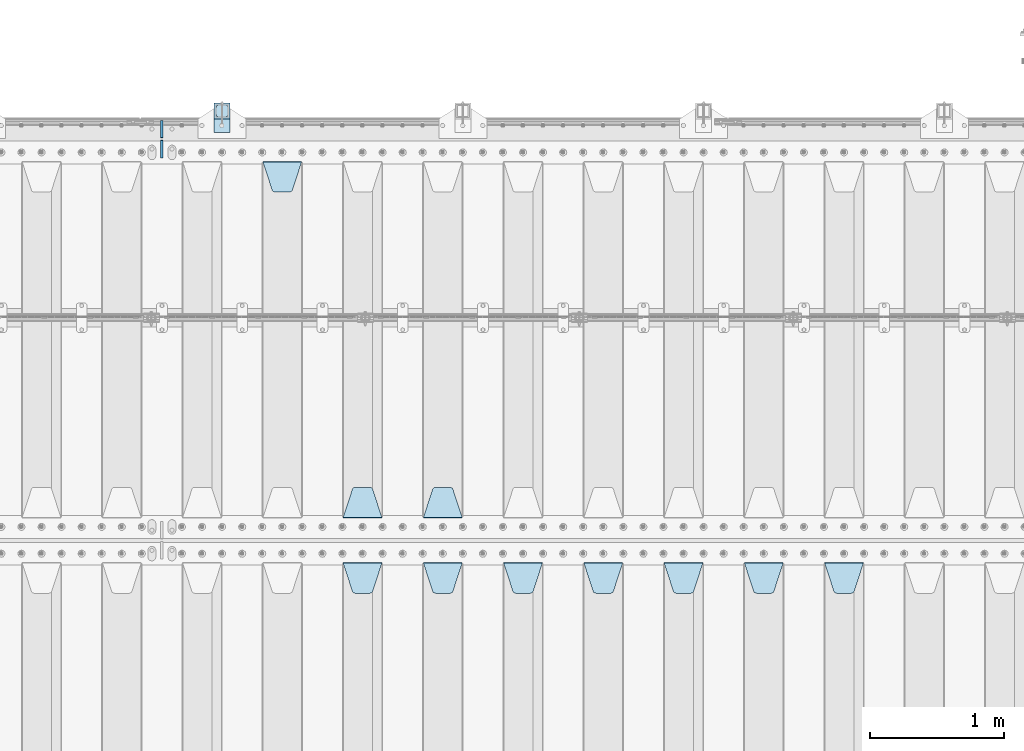
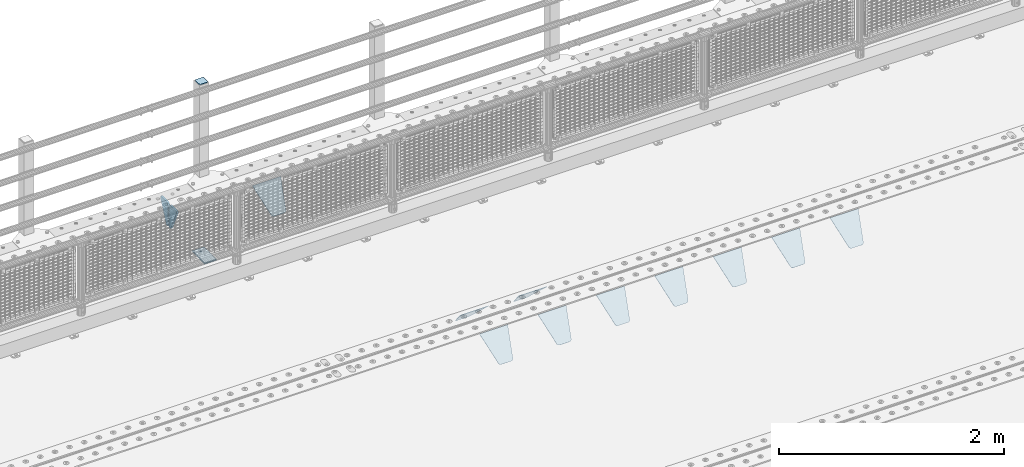
# One storey, part 224 of 257: 15 plates.
"""IFC2X3 building model written with IfcOpenShell, lengths in millimetres."""

from ifc_helpers import new_model, si_unit, frame, origin_with_axes, place, context, subcontext, project, spatial, faceted_brep, material, type_object, element, save


model = new_model("IFC2X3")

# Units and contexts
model_context = context("Model", 3, precision=1e-05, world=origin_with_axes())
body_context = subcontext(model_context, "Body", "Model", "MODEL_VIEW")
ifc_project = project(units=[si_unit("LENGTHUNIT", "METRE", prefix="MILLI"), si_unit("AREAUNIT", "SQUARE_METRE"), si_unit("VOLUMEUNIT", "CUBIC_METRE"), si_unit("MASSUNIT", "GRAM", prefix="KILO"), si_unit("TIMEUNIT", "SECOND"), si_unit("PLANEANGLEUNIT", "RADIAN"), si_unit("SOLIDANGLEUNIT", "STERADIAN"), si_unit("THERMODYNAMICTEMPERATUREUNIT", "DEGREE_CELSIUS"), si_unit("LUMINOUSINTENSITYUNIT", "LUMEN")], contexts=[model_context])

# Site, building, storey
site_placement = place(None, origin_with_axes())
site = spatial("IfcSite", under=ifc_project, at=site_placement, CompositionType="ELEMENT")
building_placement = place(site_placement, origin_with_axes())
building = spatial("IfcBuilding", under=site, at=building_placement, Name="Standard", CompositionType="ELEMENT")
storey_placement = place(building_placement, origin_with_axes())
storey = spatial("IfcBuildingStorey", under=building, at=storey_placement, Name="Undefined", CompositionType="ELEMENT", Elevation=0.0)

# Plates
ifc_material_1 = material(Name="STEEL/S355N")
plate_type_1 = type_object("IfcPlateType", PredefinedType="NOTDEFINED")
plate_1_placement = place(storey_placement, frame((52905.0, 8831.76776695594, -1.767766952965), z_axis=(0.0, -0.707106781186548, -0.707106781186547), x_axis=(1.0, 0.0, 0.0)))
element("IfcPlate", 1, at=plate_1_placement, inside=storey, type_object=plate_type_1, material=ifc_material_1, context=body_context, shape_type="Brep", body=[
    faceted_brep([(0.0, -2.5, 0.0), (69.345504679477, -2.50000000000091, 300.17173142483), (69.345504679477, 2.5, 300.171731424831), (0.0, 2.5, 0.0), (70.927406119954, -2.50000000000091, 304.8974424154), (70.927406119954, 2.5, 304.8974424154), (73.3818627772271, -2.50000000000091, 309.234538108527), (73.3818627772271, 2.49999999999909, 309.234538108527), (76.6187032999587, -2.5, 313.023683126103), (76.6187032999587, 2.5, 313.023683126103), (80.5190132705029, -2.5, 316.125672595372), (80.5190132705029, 2.5, 316.125672595371), (84.9395038596849, -2.5, 318.426546230476), (84.9395038596849, 2.5, 318.426546230477), (89.7177759439219, -2.5, 319.841774983275), (89.7177759439219, 2.5, 319.841774983275), (94.6782862926484, -2.5, 320.319366455079), (94.6782862926484, 2.5, 320.319366455079), (195.321713707352, -2.5, 320.319366455079), (195.321713707352, 2.5, 320.319366455079), (200.282224056078, -2.5, 319.841774983275), (200.282224056078, 2.49999999999909, 319.841774983275), (205.060496140315, -2.5, 318.426546230476), (205.060496140315, 2.49999999999909, 318.426546230475), (209.480986729497, -2.5, 316.125672595371), (209.480986729497, 2.5, 316.125672595371), (213.381296700041, -2.50000000000091, 313.023683126102), (213.381296700041, 2.5, 313.023683126103), (216.618137222766, -2.50000000000091, 309.234538108527), (216.618137222766, 2.5, 309.234538108527), (219.072593880039, -2.5, 304.897442415399), (219.072593880039, 2.5, 304.897442415399), (220.654495320523, -2.50000000000091, 300.17173142483), (220.654495320523, 2.5, 300.171731424831), (290.0, -2.50000000000091, 0.0), (290.0, 2.5, 9.09494701772928e-13)], [[[0, 1, 2, 3]], [[1, 4, 5, 2]], [[4, 6, 7, 5]], [[6, 8, 9, 7]], [[8, 10, 11, 9]], [[10, 12, 13, 11]], [[12, 14, 15, 13]], [[14, 16, 17, 15]], [[16, 18, 19, 17]], [[18, 20, 21, 19]], [[20, 22, 23, 21]], [[22, 24, 25, 23]], [[24, 26, 27, 25]], [[26, 28, 29, 27]], [[28, 30, 31, 29]], [[30, 32, 33, 31]], [[32, 34, 35, 33]], [[34, 0, 3, 35]], [[5, 7, 9, 11, 13, 15, 17, 19, 21, 23, 25, 27, 29, 31, 33, 35, 3, 2]], [[34, 32, 30, 28, 26, 24, 22, 20, 18, 16, 14, 12, 10, 8, 6, 4, 1, 0]]]),
])
plate_2_placement = place(storey_placement, frame((52305.0, 8831.76776695594, -1.767766952965), z_axis=(0.0, -0.707106781186548, -0.707106781186547), x_axis=(1.0, 0.0, 0.0)))
element("IfcPlate", 2, at=plate_2_placement, inside=storey, type_object=plate_type_1, material=ifc_material_1, context=body_context, shape_type="Brep", body=[
    faceted_brep([(0.0, -2.5, 0.0), (69.345504679477, -2.50000000000091, 300.17173142483), (69.345504679477, 2.5, 300.171731424831), (0.0, 2.5, 0.0), (70.927406119954, -2.50000000000091, 304.8974424154), (70.927406119954, 2.5, 304.8974424154), (73.3818627772271, -2.50000000000091, 309.234538108527), (73.3818627772271, 2.49999999999909, 309.234538108527), (76.6187032999587, -2.5, 313.023683126103), (76.6187032999587, 2.5, 313.023683126103), (80.5190132705029, -2.5, 316.125672595372), (80.5190132705029, 2.5, 316.125672595371), (84.9395038596849, -2.5, 318.426546230476), (84.9395038596849, 2.5, 318.426546230477), (89.7177759439219, -2.5, 319.841774983275), (89.7177759439219, 2.5, 319.841774983275), (94.6782862926484, -2.5, 320.319366455079), (94.6782862926484, 2.5, 320.319366455079), (195.321713707352, -2.5, 320.319366455079), (195.321713707352, 2.5, 320.319366455079), (200.282224056078, -2.5, 319.841774983275), (200.282224056078, 2.49999999999909, 319.841774983275), (205.060496140315, -2.5, 318.426546230476), (205.060496140315, 2.49999999999909, 318.426546230475), (209.480986729497, -2.5, 316.125672595371), (209.480986729497, 2.5, 316.125672595371), (213.381296700041, -2.50000000000091, 313.023683126102), (213.381296700041, 2.5, 313.023683126103), (216.618137222766, -2.50000000000091, 309.234538108527), (216.618137222766, 2.5, 309.234538108527), (219.072593880039, -2.5, 304.897442415399), (219.072593880039, 2.5, 304.897442415399), (220.654495320523, -2.50000000000091, 300.17173142483), (220.654495320523, 2.5, 300.171731424831), (290.0, -2.50000000000091, 0.0), (290.0, 2.5, 9.09494701772928e-13)], [[[0, 1, 2, 3]], [[1, 4, 5, 2]], [[4, 6, 7, 5]], [[6, 8, 9, 7]], [[8, 10, 11, 9]], [[10, 12, 13, 11]], [[12, 14, 15, 13]], [[14, 16, 17, 15]], [[16, 18, 19, 17]], [[18, 20, 21, 19]], [[20, 22, 23, 21]], [[22, 24, 25, 23]], [[24, 26, 27, 25]], [[26, 28, 29, 27]], [[28, 30, 31, 29]], [[30, 32, 33, 31]], [[32, 34, 35, 33]], [[34, 0, 3, 35]], [[5, 7, 9, 11, 13, 15, 17, 19, 21, 23, 25, 27, 29, 31, 33, 35, 3, 2]], [[34, 32, 30, 28, 26, 24, 22, 20, 18, 16, 14, 12, 10, 8, 6, 4, 1, 0]]]),
])
plate_3_placement = place(storey_placement, frame((51705.0, 8831.76776695594, -1.767766952965), z_axis=(0.0, -0.707106781186548, -0.707106781186547), x_axis=(1.0, 0.0, 0.0)))
element("IfcPlate", 3, at=plate_3_placement, inside=storey, type_object=plate_type_1, material=ifc_material_1, context=body_context, shape_type="Brep", body=[
    faceted_brep([(0.0, -2.5, 0.0), (69.345504679477, -2.50000000000091, 300.17173142483), (69.345504679477, 2.5, 300.171731424831), (0.0, 2.5, 0.0), (70.927406119954, -2.50000000000091, 304.8974424154), (70.927406119954, 2.5, 304.8974424154), (73.3818627772271, -2.50000000000091, 309.234538108527), (73.3818627772271, 2.49999999999909, 309.234538108527), (76.6187032999587, -2.5, 313.023683126103), (76.6187032999587, 2.5, 313.023683126103), (80.5190132705029, -2.5, 316.125672595372), (80.5190132705029, 2.5, 316.125672595371), (84.9395038596849, -2.5, 318.426546230476), (84.9395038596849, 2.5, 318.426546230477), (89.7177759439219, -2.5, 319.841774983275), (89.7177759439219, 2.5, 319.841774983275), (94.6782862926484, -2.5, 320.319366455079), (94.6782862926484, 2.5, 320.319366455079), (195.321713707352, -2.5, 320.319366455079), (195.321713707352, 2.5, 320.319366455079), (200.282224056078, -2.5, 319.841774983275), (200.282224056078, 2.49999999999909, 319.841774983275), (205.060496140315, -2.5, 318.426546230476), (205.060496140315, 2.49999999999909, 318.426546230475), (209.480986729497, -2.5, 316.125672595371), (209.480986729497, 2.5, 316.125672595371), (213.381296700041, -2.50000000000091, 313.023683126102), (213.381296700041, 2.5, 313.023683126103), (216.618137222766, -2.50000000000091, 309.234538108527), (216.618137222766, 2.5, 309.234538108527), (219.072593880039, -2.5, 304.897442415399), (219.072593880039, 2.5, 304.897442415399), (220.654495320523, -2.50000000000091, 300.17173142483), (220.654495320523, 2.5, 300.171731424831), (290.0, -2.50000000000091, 0.0), (290.0, 2.5, 9.09494701772928e-13)], [[[0, 1, 2, 3]], [[1, 4, 5, 2]], [[4, 6, 7, 5]], [[6, 8, 9, 7]], [[8, 10, 11, 9]], [[10, 12, 13, 11]], [[12, 14, 15, 13]], [[14, 16, 17, 15]], [[16, 18, 19, 17]], [[18, 20, 21, 19]], [[20, 22, 23, 21]], [[22, 24, 25, 23]], [[24, 26, 27, 25]], [[26, 28, 29, 27]], [[28, 30, 31, 29]], [[30, 32, 33, 31]], [[32, 34, 35, 33]], [[34, 0, 3, 35]], [[5, 7, 9, 11, 13, 15, 17, 19, 21, 23, 25, 27, 29, 31, 33, 35, 3, 2]], [[34, 32, 30, 28, 26, 24, 22, 20, 18, 16, 14, 12, 10, 8, 6, 4, 1, 0]]]),
])
plate_4_placement = place(storey_placement, frame((51105.0, 8831.76776695594, -1.767766952965), z_axis=(0.0, -0.707106781186548, -0.707106781186547), x_axis=(1.0, 0.0, 0.0)))
element("IfcPlate", 4, at=plate_4_placement, inside=storey, type_object=plate_type_1, material=ifc_material_1, context=body_context, shape_type="Brep", body=[
    faceted_brep([(0.0, -2.5, 0.0), (69.345504679477, -2.50000000000091, 300.17173142483), (69.345504679477, 2.5, 300.171731424831), (0.0, 2.5, 0.0), (70.927406119954, -2.50000000000091, 304.8974424154), (70.927406119954, 2.5, 304.8974424154), (73.3818627772271, -2.50000000000091, 309.234538108527), (73.3818627772271, 2.49999999999909, 309.234538108527), (76.6187032999587, -2.5, 313.023683126103), (76.6187032999587, 2.5, 313.023683126103), (80.5190132705029, -2.5, 316.125672595372), (80.5190132705029, 2.5, 316.125672595371), (84.9395038596849, -2.5, 318.426546230476), (84.9395038596849, 2.5, 318.426546230477), (89.7177759439219, -2.5, 319.841774983275), (89.7177759439219, 2.5, 319.841774983275), (94.6782862926484, -2.5, 320.319366455079), (94.6782862926484, 2.5, 320.319366455079), (195.321713707352, -2.5, 320.319366455079), (195.321713707352, 2.5, 320.319366455079), (200.282224056078, -2.5, 319.841774983275), (200.282224056078, 2.49999999999909, 319.841774983275), (205.060496140315, -2.5, 318.426546230476), (205.060496140315, 2.49999999999909, 318.426546230475), (209.480986729497, -2.5, 316.125672595371), (209.480986729497, 2.5, 316.125672595371), (213.381296700041, -2.50000000000091, 313.023683126102), (213.381296700041, 2.5, 313.023683126103), (216.618137222766, -2.50000000000091, 309.234538108527), (216.618137222766, 2.5, 309.234538108527), (219.072593880039, -2.5, 304.897442415399), (219.072593880039, 2.5, 304.897442415399), (220.654495320523, -2.50000000000091, 300.17173142483), (220.654495320523, 2.5, 300.171731424831), (290.0, -2.50000000000091, 0.0), (290.0, 2.5, 9.09494701772928e-13)], [[[0, 1, 2, 3]], [[1, 4, 5, 2]], [[4, 6, 7, 5]], [[6, 8, 9, 7]], [[8, 10, 11, 9]], [[10, 12, 13, 11]], [[12, 14, 15, 13]], [[14, 16, 17, 15]], [[16, 18, 19, 17]], [[18, 20, 21, 19]], [[20, 22, 23, 21]], [[22, 24, 25, 23]], [[24, 26, 27, 25]], [[26, 28, 29, 27]], [[28, 30, 31, 29]], [[30, 32, 33, 31]], [[32, 34, 35, 33]], [[34, 0, 3, 35]], [[5, 7, 9, 11, 13, 15, 17, 19, 21, 23, 25, 27, 29, 31, 33, 35, 3, 2]], [[34, 32, 30, 28, 26, 24, 22, 20, 18, 16, 14, 12, 10, 8, 6, 4, 1, 0]]]),
])
plate_5_placement = place(storey_placement, frame((50505.0, 8831.76776695594, -1.767766952965), z_axis=(0.0, -0.707106781186548, -0.707106781186547), x_axis=(1.0, 0.0, 0.0)))
element("IfcPlate", 5, at=plate_5_placement, inside=storey, type_object=plate_type_1, material=ifc_material_1, context=body_context, shape_type="Brep", body=[
    faceted_brep([(0.0, -2.5, 0.0), (69.345504679477, -2.50000000000091, 300.17173142483), (69.345504679477, 2.5, 300.171731424831), (0.0, 2.5, 0.0), (70.927406119954, -2.50000000000091, 304.8974424154), (70.927406119954, 2.5, 304.8974424154), (73.3818627772271, -2.50000000000091, 309.234538108527), (73.3818627772271, 2.49999999999909, 309.234538108527), (76.6187032999587, -2.5, 313.023683126103), (76.6187032999587, 2.5, 313.023683126103), (80.5190132705029, -2.5, 316.125672595372), (80.5190132705029, 2.5, 316.125672595371), (84.9395038596849, -2.5, 318.426546230476), (84.9395038596849, 2.5, 318.426546230477), (89.7177759439219, -2.5, 319.841774983275), (89.7177759439219, 2.5, 319.841774983275), (94.6782862926484, -2.5, 320.319366455079), (94.6782862926484, 2.5, 320.319366455079), (195.321713707352, -2.5, 320.319366455079), (195.321713707352, 2.5, 320.319366455079), (200.282224056078, -2.5, 319.841774983275), (200.282224056078, 2.49999999999909, 319.841774983275), (205.060496140315, -2.5, 318.426546230476), (205.060496140315, 2.49999999999909, 318.426546230475), (209.480986729497, -2.5, 316.125672595371), (209.480986729497, 2.5, 316.125672595371), (213.381296700041, -2.50000000000091, 313.023683126102), (213.381296700041, 2.5, 313.023683126103), (216.618137222766, -2.50000000000091, 309.234538108527), (216.618137222766, 2.5, 309.234538108527), (219.072593880039, -2.5, 304.897442415399), (219.072593880039, 2.5, 304.897442415399), (220.654495320523, -2.50000000000091, 300.17173142483), (220.654495320523, 2.5, 300.171731424831), (290.0, -2.50000000000091, 0.0), (290.0, 2.5, 9.09494701772928e-13)], [[[0, 1, 2, 3]], [[1, 4, 5, 2]], [[4, 6, 7, 5]], [[6, 8, 9, 7]], [[8, 10, 11, 9]], [[10, 12, 13, 11]], [[12, 14, 15, 13]], [[14, 16, 17, 15]], [[16, 18, 19, 17]], [[18, 20, 21, 19]], [[20, 22, 23, 21]], [[22, 24, 25, 23]], [[24, 26, 27, 25]], [[26, 28, 29, 27]], [[28, 30, 31, 29]], [[30, 32, 33, 31]], [[32, 34, 35, 33]], [[34, 0, 3, 35]], [[5, 7, 9, 11, 13, 15, 17, 19, 21, 23, 25, 27, 29, 31, 33, 35, 3, 2]], [[34, 32, 30, 28, 26, 24, 22, 20, 18, 16, 14, 12, 10, 8, 6, 4, 1, 0]]]),
])
plate_6_placement = place(storey_placement, frame((49905.0, 8831.76776695594, -1.767766952965), z_axis=(0.0, -0.707106781186548, -0.707106781186547), x_axis=(1.0, 0.0, 0.0)))
element("IfcPlate", 6, at=plate_6_placement, inside=storey, type_object=plate_type_1, material=ifc_material_1, context=body_context, shape_type="Brep", body=[
    faceted_brep([(0.0, -2.5, 0.0), (69.345504679477, -2.50000000000091, 300.17173142483), (69.345504679477, 2.5, 300.171731424831), (0.0, 2.5, 0.0), (70.927406119954, -2.50000000000091, 304.8974424154), (70.927406119954, 2.5, 304.8974424154), (73.3818627772271, -2.50000000000091, 309.234538108527), (73.3818627772271, 2.49999999999909, 309.234538108527), (76.6187032999587, -2.5, 313.023683126103), (76.6187032999587, 2.5, 313.023683126103), (80.5190132705029, -2.5, 316.125672595372), (80.5190132705029, 2.5, 316.125672595371), (84.9395038596849, -2.5, 318.426546230476), (84.9395038596849, 2.5, 318.426546230477), (89.7177759439219, -2.5, 319.841774983275), (89.7177759439219, 2.5, 319.841774983275), (94.6782862926484, -2.5, 320.319366455079), (94.6782862926484, 2.5, 320.319366455079), (195.321713707352, -2.5, 320.319366455079), (195.321713707352, 2.5, 320.319366455079), (200.282224056078, -2.5, 319.841774983275), (200.282224056078, 2.49999999999909, 319.841774983275), (205.060496140315, -2.5, 318.426546230476), (205.060496140315, 2.49999999999909, 318.426546230475), (209.480986729497, -2.5, 316.125672595371), (209.480986729497, 2.5, 316.125672595371), (213.381296700041, -2.50000000000091, 313.023683126102), (213.381296700041, 2.5, 313.023683126103), (216.618137222766, -2.50000000000091, 309.234538108527), (216.618137222766, 2.5, 309.234538108527), (219.072593880039, -2.5, 304.897442415399), (219.072593880039, 2.5, 304.897442415399), (220.654495320523, -2.50000000000091, 300.17173142483), (220.654495320523, 2.5, 300.171731424831), (290.0, -2.50000000000091, 0.0), (290.0, 2.5, 9.09494701772928e-13)], [[[0, 1, 2, 3]], [[1, 4, 5, 2]], [[4, 6, 7, 5]], [[6, 8, 9, 7]], [[8, 10, 11, 9]], [[10, 12, 13, 11]], [[12, 14, 15, 13]], [[14, 16, 17, 15]], [[16, 18, 19, 17]], [[18, 20, 21, 19]], [[20, 22, 23, 21]], [[22, 24, 25, 23]], [[24, 26, 27, 25]], [[26, 28, 29, 27]], [[28, 30, 31, 29]], [[30, 32, 33, 31]], [[32, 34, 35, 33]], [[34, 0, 3, 35]], [[5, 7, 9, 11, 13, 15, 17, 19, 21, 23, 25, 27, 29, 31, 33, 35, 3, 2]], [[34, 32, 30, 28, 26, 24, 22, 20, 18, 16, 14, 12, 10, 8, 6, 4, 1, 0]]]),
])
plate_7_placement = place(storey_placement, frame((49305.0, 8831.76776695594, -1.767766952965), z_axis=(0.0, -0.707106781186548, -0.707106781186547), x_axis=(1.0, 0.0, 0.0)))
element("IfcPlate", 7, at=plate_7_placement, inside=storey, type_object=plate_type_1, material=ifc_material_1, context=body_context, shape_type="Brep", body=[
    faceted_brep([(0.0, -2.5, 0.0), (69.345504679477, -2.50000000000091, 300.17173142483), (69.345504679477, 2.5, 300.171731424831), (0.0, 2.5, 0.0), (70.927406119954, -2.50000000000091, 304.8974424154), (70.927406119954, 2.5, 304.8974424154), (73.3818627772271, -2.50000000000091, 309.234538108527), (73.3818627772271, 2.49999999999909, 309.234538108527), (76.6187032999587, -2.5, 313.023683126103), (76.6187032999587, 2.5, 313.023683126103), (80.5190132705029, -2.5, 316.125672595372), (80.5190132705029, 2.5, 316.125672595371), (84.9395038596849, -2.5, 318.426546230476), (84.9395038596849, 2.5, 318.426546230477), (89.7177759439219, -2.5, 319.841774983275), (89.7177759439219, 2.5, 319.841774983275), (94.6782862926484, -2.5, 320.319366455079), (94.6782862926484, 2.5, 320.319366455079), (195.321713707352, -2.5, 320.319366455079), (195.321713707352, 2.5, 320.319366455079), (200.282224056078, -2.5, 319.841774983275), (200.282224056078, 2.49999999999909, 319.841774983275), (205.060496140315, -2.5, 318.426546230476), (205.060496140315, 2.49999999999909, 318.426546230475), (209.480986729497, -2.5, 316.125672595371), (209.480986729497, 2.5, 316.125672595371), (213.381296700041, -2.50000000000091, 313.023683126102), (213.381296700041, 2.5, 313.023683126103), (216.618137222766, -2.50000000000091, 309.234538108527), (216.618137222766, 2.5, 309.234538108527), (219.072593880039, -2.5, 304.897442415399), (219.072593880039, 2.5, 304.897442415399), (220.654495320523, -2.50000000000091, 300.17173142483), (220.654495320523, 2.5, 300.171731424831), (290.0, -2.50000000000091, 0.0), (290.0, 2.5, 9.09494701772928e-13)], [[[0, 1, 2, 3]], [[1, 4, 5, 2]], [[4, 6, 7, 5]], [[6, 8, 9, 7]], [[8, 10, 11, 9]], [[10, 12, 13, 11]], [[12, 14, 15, 13]], [[14, 16, 17, 15]], [[16, 18, 19, 17]], [[18, 20, 21, 19]], [[20, 22, 23, 21]], [[22, 24, 25, 23]], [[24, 26, 27, 25]], [[26, 28, 29, 27]], [[28, 30, 31, 29]], [[30, 32, 33, 31]], [[32, 34, 35, 33]], [[34, 0, 3, 35]], [[5, 7, 9, 11, 13, 15, 17, 19, 21, 23, 25, 27, 29, 31, 33, 35, 3, 2]], [[34, 32, 30, 28, 26, 24, 22, 20, 18, 16, 14, 12, 10, 8, 6, 4, 1, 0]]]),
])
plate_8_placement = place(storey_placement, frame((50195.0, 9168.23223304703, -1.76776695296758), z_axis=(0.0, 0.707106781186547, -0.707106781186548), x_axis=(-1.0, 0.0, 0.0)))
element("IfcPlate", 8, at=plate_8_placement, inside=storey, type_object=plate_type_1, material=ifc_material_1, context=body_context, shape_type="Brep", body=[
    faceted_brep([(0.0, -2.5, 0.0), (69.345504679477, -2.50000000000091, 300.17173142483), (69.345504679477, 2.5, 300.171731424831), (0.0, 2.5, 0.0), (70.927406119954, -2.50000000000091, 304.8974424154), (70.927406119954, 2.5, 304.8974424154), (73.3818627772271, -2.50000000000091, 309.234538108527), (73.3818627772271, 2.49999999999909, 309.234538108527), (76.6187032999587, -2.5, 313.023683126103), (76.6187032999587, 2.5, 313.023683126103), (80.5190132705029, -2.5, 316.125672595372), (80.5190132705029, 2.5, 316.125672595371), (84.9395038596849, -2.5, 318.426546230476), (84.9395038596849, 2.5, 318.426546230477), (89.7177759439219, -2.5, 319.841774983275), (89.7177759439219, 2.5, 319.841774983275), (94.6782862926484, -2.5, 320.319366455079), (94.6782862926484, 2.5, 320.319366455079), (195.321713707352, -2.5, 320.319366455079), (195.321713707352, 2.5, 320.319366455079), (200.282224056078, -2.5, 319.841774983275), (200.282224056078, 2.49999999999909, 319.841774983275), (205.060496140315, -2.5, 318.426546230476), (205.060496140315, 2.49999999999909, 318.426546230475), (209.480986729497, -2.5, 316.125672595371), (209.480986729497, 2.5, 316.125672595371), (213.381296700041, -2.50000000000091, 313.023683126102), (213.381296700041, 2.5, 313.023683126103), (216.618137222766, -2.50000000000091, 309.234538108527), (216.618137222766, 2.5, 309.234538108527), (219.072593880039, -2.5, 304.897442415399), (219.072593880039, 2.5, 304.897442415399), (220.654495320523, -2.50000000000091, 300.17173142483), (220.654495320523, 2.5, 300.171731424831), (290.0, -2.50000000000091, 0.0), (290.0, 2.5, 9.09494701772928e-13)], [[[0, 1, 2, 3]], [[1, 4, 5, 2]], [[4, 6, 7, 5]], [[6, 8, 9, 7]], [[8, 10, 11, 9]], [[10, 12, 13, 11]], [[12, 14, 15, 13]], [[14, 16, 17, 15]], [[16, 18, 19, 17]], [[18, 20, 21, 19]], [[20, 22, 23, 21]], [[22, 24, 25, 23]], [[24, 26, 27, 25]], [[26, 28, 29, 27]], [[28, 30, 31, 29]], [[30, 32, 33, 31]], [[32, 34, 35, 33]], [[34, 0, 3, 35]], [[5, 7, 9, 11, 13, 15, 17, 19, 21, 23, 25, 27, 29, 31, 33, 35, 3, 2]], [[34, 32, 30, 28, 26, 24, 22, 20, 18, 16, 14, 12, 10, 8, 6, 4, 1, 0]]]),
])
plate_9_placement = place(storey_placement, frame((49595.0, 9168.23223304703, -1.76776695296758), z_axis=(0.0, 0.707106781186547, -0.707106781186548), x_axis=(-1.0, 0.0, 0.0)))
element("IfcPlate", 9, at=plate_9_placement, inside=storey, type_object=plate_type_1, material=ifc_material_1, context=body_context, shape_type="Brep", body=[
    faceted_brep([(0.0, -2.5, 0.0), (69.345504679477, -2.50000000000091, 300.17173142483), (69.345504679477, 2.5, 300.171731424831), (0.0, 2.5, 0.0), (70.927406119954, -2.50000000000091, 304.8974424154), (70.927406119954, 2.5, 304.8974424154), (73.3818627772271, -2.50000000000091, 309.234538108527), (73.3818627772271, 2.49999999999909, 309.234538108527), (76.6187032999587, -2.5, 313.023683126103), (76.6187032999587, 2.5, 313.023683126103), (80.5190132705029, -2.5, 316.125672595372), (80.5190132705029, 2.5, 316.125672595371), (84.9395038596849, -2.5, 318.426546230476), (84.9395038596849, 2.5, 318.426546230477), (89.7177759439219, -2.5, 319.841774983275), (89.7177759439219, 2.5, 319.841774983275), (94.6782862926484, -2.5, 320.319366455079), (94.6782862926484, 2.5, 320.319366455079), (195.321713707352, -2.5, 320.319366455079), (195.321713707352, 2.5, 320.319366455079), (200.282224056078, -2.5, 319.841774983275), (200.282224056078, 2.49999999999909, 319.841774983275), (205.060496140315, -2.5, 318.426546230476), (205.060496140315, 2.49999999999909, 318.426546230475), (209.480986729497, -2.5, 316.125672595371), (209.480986729497, 2.5, 316.125672595371), (213.381296700041, -2.50000000000091, 313.023683126102), (213.381296700041, 2.5, 313.023683126103), (216.618137222766, -2.50000000000091, 309.234538108527), (216.618137222766, 2.5, 309.234538108527), (219.072593880039, -2.5, 304.897442415399), (219.072593880039, 2.5, 304.897442415399), (220.654495320523, -2.50000000000091, 300.17173142483), (220.654495320523, 2.5, 300.171731424831), (290.0, -2.50000000000091, 0.0), (290.0, 2.5, 9.09494701772928e-13)], [[[0, 1, 2, 3]], [[1, 4, 5, 2]], [[4, 6, 7, 5]], [[6, 8, 9, 7]], [[8, 10, 11, 9]], [[10, 12, 13, 11]], [[12, 14, 15, 13]], [[14, 16, 17, 15]], [[16, 18, 19, 17]], [[18, 20, 21, 19]], [[20, 22, 23, 21]], [[22, 24, 25, 23]], [[24, 26, 27, 25]], [[26, 28, 29, 27]], [[28, 30, 31, 29]], [[30, 32, 33, 31]], [[32, 34, 35, 33]], [[34, 0, 3, 35]], [[5, 7, 9, 11, 13, 15, 17, 19, 21, 23, 25, 27, 29, 31, 33, 35, 3, 2]], [[34, 32, 30, 28, 26, 24, 22, 20, 18, 16, 14, 12, 10, 8, 6, 4, 1, 0]]]),
])
plate_10_placement = place(storey_placement, frame((48705.0, 11831.7677669559, -1.767766952965), z_axis=(0.0, -0.707106781186548, -0.707106781186547), x_axis=(1.0, 0.0, 0.0)))
element("IfcPlate", 10, at=plate_10_placement, inside=storey, type_object=plate_type_1, material=ifc_material_1, context=body_context, shape_type="Brep", body=[
    faceted_brep([(0.0, -2.5, 0.0), (69.345504679477, -2.50000000000091, 300.17173142483), (69.345504679477, 2.5, 300.171731424831), (0.0, 2.5, 0.0), (70.927406119954, -2.50000000000091, 304.8974424154), (70.927406119954, 2.5, 304.8974424154), (73.3818627772271, -2.50000000000091, 309.234538108527), (73.3818627772271, 2.49999999999909, 309.234538108527), (76.6187032999587, -2.5, 313.023683126103), (76.6187032999587, 2.5, 313.023683126103), (80.5190132705029, -2.5, 316.125672595372), (80.5190132705029, 2.5, 316.125672595371), (84.9395038596849, -2.5, 318.426546230476), (84.9395038596849, 2.5, 318.426546230477), (89.7177759439219, -2.5, 319.841774983275), (89.7177759439219, 2.5, 319.841774983275), (94.6782862926484, -2.5, 320.319366455079), (94.6782862926484, 2.5, 320.319366455079), (195.321713707352, -2.5, 320.319366455079), (195.321713707352, 2.5, 320.319366455079), (200.282224056078, -2.5, 319.841774983275), (200.282224056078, 2.49999999999909, 319.841774983275), (205.060496140315, -2.5, 318.426546230476), (205.060496140315, 2.49999999999909, 318.426546230475), (209.480986729497, -2.5, 316.125672595371), (209.480986729497, 2.5, 316.125672595371), (213.381296700041, -2.50000000000091, 313.023683126102), (213.381296700041, 2.5, 313.023683126103), (216.618137222766, -2.50000000000091, 309.234538108527), (216.618137222766, 2.5, 309.234538108527), (219.072593880039, -2.5, 304.897442415399), (219.072593880039, 2.5, 304.897442415399), (220.654495320523, -2.50000000000091, 300.17173142483), (220.654495320523, 2.5, 300.171731424831), (290.0, -2.50000000000091, 0.0), (290.0, 2.5, 9.09494701772928e-13)], [[[0, 1, 2, 3]], [[1, 4, 5, 2]], [[4, 6, 7, 5]], [[6, 8, 9, 7]], [[8, 10, 11, 9]], [[10, 12, 13, 11]], [[12, 14, 15, 13]], [[14, 16, 17, 15]], [[16, 18, 19, 17]], [[18, 20, 21, 19]], [[20, 22, 23, 21]], [[22, 24, 25, 23]], [[24, 26, 27, 25]], [[26, 28, 29, 27]], [[28, 30, 31, 29]], [[30, 32, 33, 31]], [[32, 34, 35, 33]], [[34, 0, 3, 35]], [[5, 7, 9, 11, 13, 15, 17, 19, 21, 23, 25, 27, 29, 31, 33, 35, 3, 2]], [[34, 32, 30, 28, 26, 24, 22, 20, 18, 16, 14, 12, 10, 8, 6, 4, 1, 0]]]),
])
plate_type_2 = type_object("IfcPlateType", PredefinedType="NOTDEFINED")
for number, where, z_axis, x_axis in (
    (11, (47950.0, 12140.0, -30.0), (0.0, 0.0, -1.0), (0.0, -1.0, 0.0)),
    (12, (47950.0, 11860.0, -30.0), (0.0, 0.0, -1.0), (0.0, 1.0, 0.0)),
):
    element("IfcPlate", number, at=place(storey_placement, frame(where, z_axis=z_axis, x_axis=x_axis)), inside=storey, type_object=plate_type_2, material=ifc_material_1, context=body_context, shape_type="Brep", body=[
        faceted_brep([(0.0, -10.0, 0.0), (0.0, -10.0, 30.0), (0.0, 10.0, 30.0), (0.0, 10.0, 0.0), (102.0, -10.0, 250.0), (102.0, 10.0, 250.0), (132.0, -10.0, 250.0), (132.0, 10.0, 250.0), (132.0, -10.0, 30.0), (132.0, 10.0, 30.0), (131.544232590366, -10.0, 24.790554669992), (131.544232590366, 10.0, 24.790554669992), (130.190778623577, -10.0, 19.7393957002299), (130.190778623577, 10.0, 19.7393957002299), (127.980762113533, -10.0, 15.0), (127.980762113533, 10.0, 15.0), (124.981333293569, -10.0, 10.7163717094038), (124.981333293569, 10.0, 10.7163717094038), (121.283628290596, -10.0, 7.01866670643062), (121.283628290596, 10.0, 7.01866670643062), (117.0, -10.0, 4.01923788646684), (117.0, 10.0, 4.01923788646684), (112.26060429977, -10.0, 1.80922137642278), (112.26060429977, 10.0, 1.80922137642278), (107.209445330008, -10.0, 0.455767409633722), (107.209445330008, 10.0, 0.455767409633722), (102.0, -10.0, 0.0), (102.0, 10.0, 0.0)], [[[0, 1, 2, 3]], [[1, 4, 5, 2]], [[4, 6, 7, 5]], [[6, 8, 9, 7]], [[8, 10, 11, 9]], [[10, 12, 13, 11]], [[12, 14, 15, 13]], [[14, 16, 17, 15]], [[16, 18, 19, 17]], [[18, 20, 21, 19]], [[20, 22, 23, 21]], [[22, 24, 25, 23]], [[24, 26, 27, 25]], [[26, 0, 3, 27]], [[5, 7, 9, 11, 13, 15, 17, 19, 21, 23, 25, 27, 3, 2]], [[26, 24, 22, 20, 18, 16, 14, 12, 10, 8, 6, 4, 1, 0]]]),
    ])
ifc_material_2 = material(Name="STEEL/S355J2")
plate_type_3 = type_object("IfcPlateType", PredefinedType="NOTDEFINED")
plate_11_placement = place(storey_placement, frame((48340.0000000001, 12050.0000000002, -850.000000000002), z_axis=(0.0, 1.0, 0.0), x_axis=(1.0, 0.0, 0.0)))
element("IfcPlate", 13, at=plate_11_placement, inside=storey, type_object=plate_type_3, material=ifc_material_2, context=body_context, shape_type="Brep", body=[
    faceted_brep([(66.3639610305399, -5.0, 163.636038969113), (66.3639610305399, 5.0, 163.636038969113), (59.9999999998618, 5.0, 160.999999999791), (59.9999999998618, -5.0, 160.999999999791), (53.6360389691836, 5.0, 163.636038969113), (53.6360389691836, -5.0, 163.636038969113), (50.9999999998618, 5.0, 169.999999999791), (50.9999999998618, -5.0, 169.999999999791), (53.6360389691836, 5.0, 176.363961030469), (53.6360389691836, -5.0, 176.363961030469), (59.9999999998618, 5.0, 178.999999999791), (59.9999999998618, -5.0, 178.999999999791), (66.3639610305399, 5.0, 176.363961030469), (66.3639610305399, -5.0, 176.363961030469), (68.9999999998618, 5.0, 169.999999999791), (68.9999999998618, -5.0, 169.999999999791), (120.0, -5.0, 0.0), (120.0, -5.0, 220.0), (0.0, -5.0, 220.0), (0.0, -5.0, 0.0), (0.0, 5.0, 0.0), (120.0, 5.0, 0.0), (120.0, 5.0, 220.0), (0.0, 5.0, 220.0)], [[[0, 1, 2, 3]], [[3, 2, 4, 5]], [[5, 4, 6, 7]], [[7, 6, 8, 9]], [[9, 8, 10, 11]], [[11, 10, 12, 13]], [[13, 12, 14, 15]], [[15, 14, 1, 0]], [[16, 17, 18, 19], [3, 5, 7, 9, 11, 13, 15, 0]], [[16, 19, 20, 21]], [[17, 16, 21, 22]], [[18, 17, 22, 23]], [[19, 18, 23, 20]], [[22, 21, 20, 23], [10, 8, 6, 4, 2, 1, 14, 12]]]),
])
plate_type_4 = type_object("IfcPlateType", PredefinedType="NOTDEFINED")
plate_12_placement = place(storey_placement, frame((48444.0000000001, 12166.0000000002, 1012.50000000001), z_axis=(0.0, 1.0, 0.0), x_axis=(-1.0, 0.0, 0.0)))
element("IfcPlate", 14, at=plate_12_placement, inside=storey, type_object=plate_type_4, material=ifc_material_2, context=body_context, shape_type="Brep", body=[
    faceted_brep([(0.0, -2.5, 19.0), (0.0, -2.5, 69.0), (0.0, 2.5, 69.0), (0.0, 2.5, 19.0), (0.476369668547704, -2.5, 73.2278977451697), (0.476369668547704, 2.5, 73.2278977451697), (1.88159150985302, -2.5, 77.2437910432327), (1.88159150985302, 2.5, 77.2437910432327), (4.14520183311106, -2.5, 80.8463062353167), (4.14520183311106, 2.5, 80.8463062353167), (7.15369376468152, -2.5, 83.8547981668926), (7.15369376468152, 2.5, 83.8547981668926), (10.7562089567655, -2.5, 86.1184084901452), (10.7562089567655, 2.5, 86.1184084901452), (14.7721022548285, -2.5, 87.5236303314541), (14.7721022548285, 2.5, 87.5236303314541), (19.0, -2.5, 88.0), (19.0, 2.5, 88.0), (69.0, -2.5, 88.0), (69.0, 2.5, 88.0), (73.2278977451715, -2.5, 87.5236303314541), (73.2278977451715, 2.5, 87.5236303314541), (77.2437910432345, -2.5, 86.1184084901452), (77.2437910432345, 2.5, 86.1184084901452), (80.8463062353185, -2.5, 83.8547981668926), (80.8463062353185, 2.5, 83.8547981668926), (83.8547981668889, -2.5, 80.8463062353167), (83.8547981668889, 2.5, 80.8463062353167), (86.118408490147, -2.5, 77.2437910432327), (86.118408490147, 2.5, 77.2437910432327), (87.5236303314523, -2.5, 73.2278977451697), (87.5236303314523, 2.5, 73.2278977451697), (88.0, -2.5, 69.0), (88.0, 2.5, 69.0), (88.0, -2.5, 19.0), (88.0, 2.5, 19.0), (87.5236303314523, -2.5, 14.7721022548303), (87.5236303314523, 2.5, 14.7721022548303), (86.118408490147, -2.5, 10.7562089567673), (86.118408490147, 2.5, 10.7562089567673), (83.8547981668889, -2.5, 7.15369376468334), (83.8547981668889, 2.5, 7.15369376468334), (80.8463062353185, -2.5, 4.14520183310742), (80.8463062353185, 2.5, 4.14520183310742), (77.2437910432345, -2.5, 1.88159150985484), (77.2437910432345, 2.5, 1.88159150985484), (73.2278977451715, -2.5, 0.476369668545885), (73.2278977451715, 2.5, 0.476369668545885), (69.0, -2.5, 0.0), (69.0, 2.5, 0.0), (19.0, -2.5, 0.0), (19.0, 2.5, 0.0), (14.7721022548285, -2.5, 0.476369668545885), (14.7721022548285, 2.5, 0.476369668545885), (10.7562089567655, -2.5, 1.88159150985484), (10.7562089567655, 2.5, 1.88159150985484), (7.15369376468152, -2.5, 4.14520183310742), (7.15369376468152, 2.5, 4.14520183310742), (4.14520183311106, -2.5, 7.15369376468334), (4.14520183311106, 2.5, 7.15369376468334), (1.88159150985302, -2.5, 10.7562089567673), (1.88159150985302, 2.5, 10.7562089567673), (0.476369668547704, -2.5, 14.7721022548303), (0.476369668547704, 2.5, 14.7721022548303)], [[[0, 1, 2, 3]], [[1, 4, 5, 2]], [[4, 6, 7, 5]], [[6, 8, 9, 7]], [[8, 10, 11, 9]], [[10, 12, 13, 11]], [[12, 14, 15, 13]], [[14, 16, 17, 15]], [[16, 18, 19, 17]], [[18, 20, 21, 19]], [[20, 22, 23, 21]], [[22, 24, 25, 23]], [[24, 26, 27, 25]], [[26, 28, 29, 27]], [[28, 30, 31, 29]], [[30, 32, 33, 31]], [[32, 34, 35, 33]], [[34, 36, 37, 35]], [[36, 38, 39, 37]], [[38, 40, 41, 39]], [[40, 42, 43, 41]], [[42, 44, 45, 43]], [[44, 46, 47, 45]], [[46, 48, 49, 47]], [[48, 50, 51, 49]], [[50, 52, 53, 51]], [[52, 54, 55, 53]], [[54, 56, 57, 55]], [[56, 58, 59, 57]], [[58, 60, 61, 59]], [[60, 62, 63, 61]], [[62, 0, 3, 63]], [[5, 7, 9, 11, 13, 15, 17, 19, 21, 23, 25, 27, 29, 31, 33, 35, 37, 39, 41, 43, 45, 47, 49, 51, 53, 55, 57, 59, 61, 63, 3, 2]], [[62, 60, 58, 56, 54, 52, 50, 48, 46, 44, 42, 40, 38, 36, 34, 32, 30, 28, 26, 24, 22, 20, 18, 16, 14, 12, 10, 8, 6, 4, 1, 0]]]),
])
plate_type_5 = type_object("IfcPlateType", PredefinedType="NOTDEFINED")
plate_13_placement = place(storey_placement, frame((48340.0000000001, 12050.0000000002, -857.500000000002), z_axis=(0.0, 1.0, 0.0), x_axis=(1.0, 0.0, 0.0)))
element("IfcPlate", 15, at=plate_13_placement, inside=storey, type_object=plate_type_5, material=ifc_material_2, context=body_context, shape_type="Brep", body=[
    faceted_brep([(0.0, -2.5, 0.0), (0.0, -2.5, 100.0), (0.0, 2.5, 100.0), (0.0, 2.5, 0.0), (120.0, -2.5, 100.0), (120.0, 2.5, 100.0), (120.0, -2.5, 0.0), (120.0, 2.5, 0.0)], [[[0, 1, 2, 3]], [[1, 4, 5, 2]], [[4, 6, 7, 5]], [[6, 0, 3, 7]], [[5, 7, 3, 2]], [[6, 4, 1, 0]]]),
])

save(model, "model.ifc")
